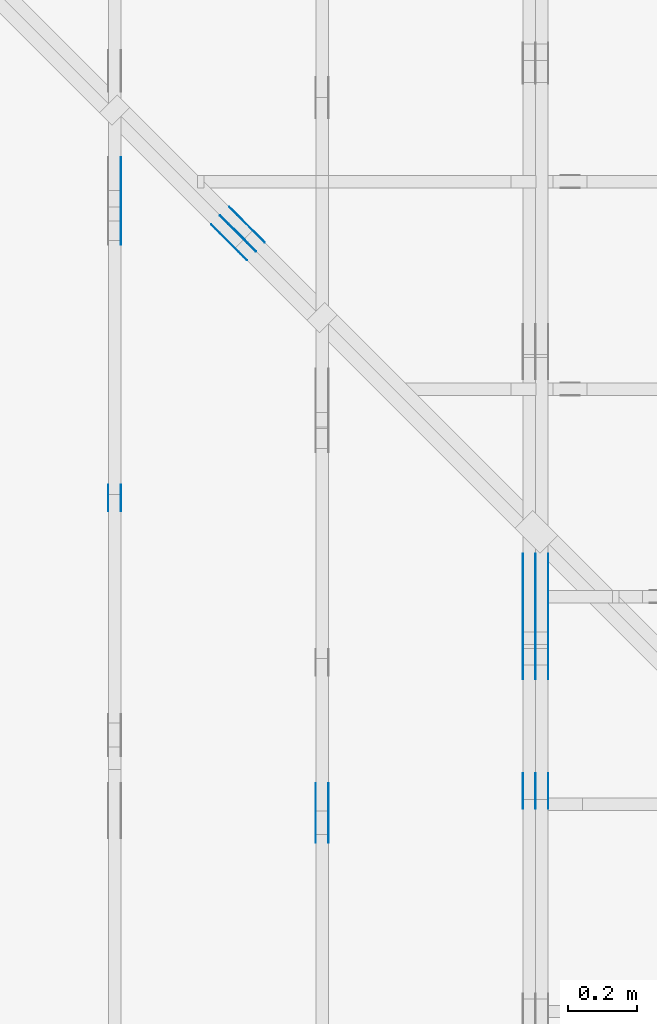
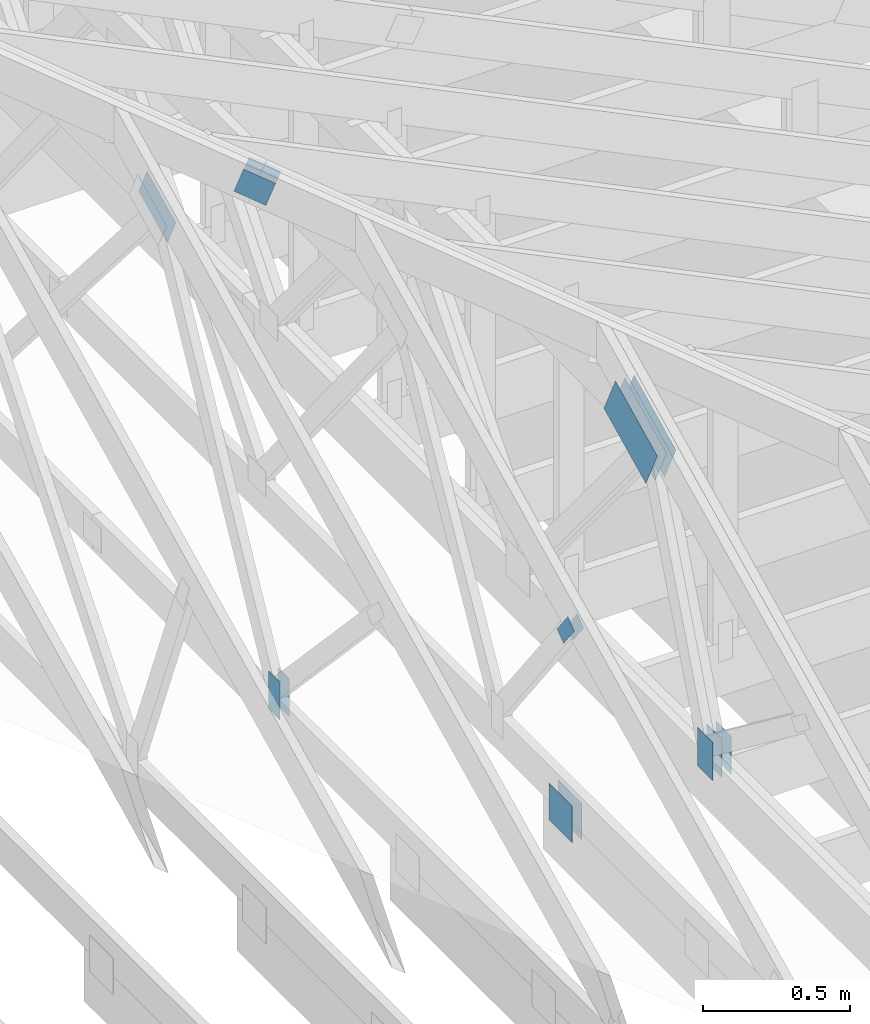
# One storey, part 115 of 159: 19 plates, 4 elements without a shape of their own.
"""IFC2X3 building model written with IfcOpenShell, lengths in millimetres."""

from ifc_helpers import new_model, si_unit, frame, origin, origin_with_axes, origin_2d, place, context, project, spatial, faceted_brep, element, aggregate, save


model = new_model("IFC2X3")

# Units and contexts
model_context = context("Model", 3, precision=1e-05, world=origin())
plan_context = context("Plan", 2, precision=1e-05, world=origin_2d())
ifc_project = project(units=[si_unit("LENGTHUNIT", "METRE", prefix="MILLI"), si_unit("AREAUNIT", "SQUARE_METRE"), si_unit("VOLUMEUNIT", "CUBIC_METRE"), si_unit("SOLIDANGLEUNIT", "STERADIAN"), si_unit("PLANEANGLEUNIT", "RADIAN"), si_unit("MASSUNIT", "GRAM"), si_unit("TIMEUNIT", "SECOND"), si_unit("THERMODYNAMICTEMPERATUREUNIT", "DEGREE_CELSIUS"), si_unit("LUMINOUSINTENSITYUNIT", "LUMEN")], contexts=[model_context, plan_context])

# Site, building, storey
site_placement = place(None, origin_with_axes())
site = spatial("IfcSite", under=ifc_project, at=site_placement, CompositionType="ELEMENT")
building_placement = place(site_placement, origin_with_axes())
building = spatial("IfcBuilding", under=site, at=building_placement, Name="Plan 1", CompositionType="ELEMENT")
storey_placement = place(building_placement, origin_with_axes())
storey = spatial("IfcBuildingStorey", under=building, at=storey_placement, Name="Etasje 1", CompositionType="ELEMENT", Elevation=0.0)

# Assembly, plates
assembly_1_placement = place(storey_placement, frame((18074.541652722903, -699.9989301294845, 4.408582873760558e-15), z_axis=(-1.0, 1.836909530733566e-16, 6.123031769111886e-17), x_axis=(-1.836909530733566e-16, -1.0, 0.0)))
assembly_1 = element("IfcElementAssembly", 1, at=assembly_1_placement, inside=storey, Name="V5 (30)", AssemblyPlace="FACTORY", PredefinedType="TRUSS")
plate_1_placement = place(assembly_1_placement, frame((-2561.626432245095, 1260.3537438661988, 0.0), z_axis=(0.0, 0.0, 1.0), x_axis=(-0.898794046299167, 0.4383711467890773, 0.0)))
plate_1 = element("IfcPlate", 2, at=plate_1_placement, Name="GNT100S 178x317", context=model_context, shape_type="Brep", body=[
    faceted_brep([(316.99999736103564, 177.99999490631035, 1.0), (0.0, 177.99999490631035, 1.0), (3.6269326301408e-05, 0.0, 1.0), (317.00003363036194, 0.0, 1.0), (0.0, 177.99999490631035, 0.0), (316.99999736103564, 177.99999490631035, 3.882002109300011e-14), (317.00003363036194, 3.26308529565722e-05, 3.882002553456485e-14), (3.6269326301408e-05, 3.26308529565722e-05, 4.44156474375613e-21), (317.0000882721888, 3.891293175545378e-05, 3.565444389546901e-30), (317.0000882721888, 3.891293175551501e-05, 1.0), (8.827218880469445e-05, 3.891293181374504e-05, 1.0), (8.827218880469445e-05, 3.891293181368381e-05, 1.128474576789396e-36), (317.0000882721888, 178.0000389129318, 0.0), (317.0000882721888, 178.0000389129318, 1.0), (317.0000882721888, 3.8912931813683826e-05, 1.0), (317.0000882721888, 3.8912931813683826e-05, 0.0), (8.827218925944179e-05, 178.00003891293147, 0.0), (8.827218925944179e-05, 178.00003891293147, 1.0), (317.0000882721888, 178.0000389129318, 1.0), (317.0000882721888, 178.0000389129318, 0.0), (8.827218880469445e-05, 3.891293181368383e-05, 7.52316384526264e-37), (8.827218880475568e-05, 3.891293181368383e-05, 1.0), (8.827218922179307e-05, 178.00003891293147, 1.0), (8.827218922173184e-05, 178.00003891293147, 2.3089936487439344e-30)], [[[0, 1, 2, 3]], [[4, 5, 6, 7]], [[8, 9, 10, 11]], [[12, 13, 14, 15]], [[16, 17, 18, 19]], [[20, 21, 22, 23]]]),
])
plate_2_placement = place(assembly_1_placement, frame((-2561.626432245095, 1260.3537438661988, -37.0), z_axis=(0.0, 0.0, 1.0), x_axis=(-0.898794046299167, 0.4383711467890773, 0.0)))
plate_2 = element("IfcPlate", 3, at=plate_2_placement, Name="GNT100S 178x317", context=model_context, shape_type="Brep", body=[
    faceted_brep([(316.99999736103564, 177.99999490631035, 1.0), (0.0, 177.99999490631035, 1.0), (3.6269326301408e-05, 0.0, 1.0), (317.00003363036194, 0.0, 1.0), (0.0, 177.99999490631035, 0.0), (316.99999736103564, 177.99999490631035, 3.882002109300011e-14), (317.00003363036194, 3.26308529565722e-05, 3.882002553456485e-14), (3.6269326301408e-05, 3.26308529565722e-05, 4.44156474375613e-21), (317.0000882721888, 3.891293175545378e-05, 3.565444389546901e-30), (317.0000882721888, 3.891293175551501e-05, 1.0), (8.827218880469445e-05, 3.891293181374504e-05, 1.0), (8.827218880469445e-05, 3.891293181368381e-05, 1.128474576789396e-36), (317.0000882721888, 178.0000389129318, 0.0), (317.0000882721888, 178.0000389129318, 1.0), (317.0000882721888, 3.8912931813683826e-05, 1.0), (317.0000882721888, 3.8912931813683826e-05, 0.0), (8.827218925944179e-05, 178.00003891293147, 0.0), (8.827218925944179e-05, 178.00003891293147, 1.0), (317.0000882721888, 178.0000389129318, 1.0), (317.0000882721888, 178.0000389129318, 0.0), (8.827218880469445e-05, 3.891293181368383e-05, 7.52316384526264e-37), (8.827218880475568e-05, 3.891293181368383e-05, 1.0), (8.827218922179307e-05, 178.00003891293147, 1.0), (8.827218922173184e-05, 178.00003891293147, 2.3089936487439344e-30)], [[[0, 1, 2, 3]], [[4, 5, 6, 7]], [[8, 9, 10, 11]], [[12, 13, 14, 15]], [[16, 17, 18, 19]], [[20, 21, 22, 23]]]),
])
plate_3_placement = place(assembly_1_placement, frame((-2561.626432245095, 1260.3537438661988, -36.0), z_axis=(0.0, 0.0, 1.0), x_axis=(-0.898794046299167, 0.4383711467890773, 0.0)))
plate_3 = element("IfcPlate", 4, at=plate_3_placement, Name="GNT100S 178x317", context=model_context, shape_type="Brep", body=[
    faceted_brep([(316.99999736103564, 177.99999490631035, 1.0), (0.0, 177.99999490631035, 1.0), (3.6269326301408e-05, 0.0, 1.0), (317.00003363036194, 0.0, 1.0), (0.0, 177.99999490631035, 0.0), (316.99999736103564, 177.99999490631035, 3.882002109300011e-14), (317.00003363036194, 3.26308529565722e-05, 3.882002553456485e-14), (3.6269326301408e-05, 3.26308529565722e-05, 4.44156474375613e-21), (317.0000882721888, 3.891293175545378e-05, 3.565444389546901e-30), (317.0000882721888, 3.891293175551501e-05, 1.0), (8.827218880469445e-05, 3.891293181374504e-05, 1.0), (8.827218880469445e-05, 3.891293181368381e-05, 1.128474576789396e-36), (317.0000882721888, 178.0000389129318, 0.0), (317.0000882721888, 178.0000389129318, 1.0), (317.0000882721888, 3.8912931813683826e-05, 1.0), (317.0000882721888, 3.8912931813683826e-05, 0.0), (8.827218925944179e-05, 178.00003891293147, 0.0), (8.827218925944179e-05, 178.00003891293147, 1.0), (317.0000882721888, 178.0000389129318, 1.0), (317.0000882721888, 178.0000389129318, 0.0), (8.827218880469445e-05, 3.891293181368383e-05, 7.52316384526264e-37), (8.827218880475568e-05, 3.891293181368383e-05, 1.0), (8.827218922179307e-05, 178.00003891293147, 1.0), (8.827218922173184e-05, 178.00003891293147, 2.3089936487439344e-30)], [[[0, 1, 2, 3]], [[4, 5, 6, 7]], [[8, 9, 10, 11]], [[12, 13, 14, 15]], [[16, 17, 18, 19]], [[20, 21, 22, 23]]]),
])
plate_4_placement = place(assembly_1_placement, frame((-2561.626432245095, 1260.3537438661988, -73.0), z_axis=(0.0, 0.0, 1.0), x_axis=(-0.898794046299167, 0.4383711467890773, 0.0)))
plate_4 = element("IfcPlate", 5, at=plate_4_placement, Name="GNT100S 178x317", context=model_context, shape_type="Brep", body=[
    faceted_brep([(316.99999736103564, 177.99999490631035, 1.0), (0.0, 177.99999490631035, 1.0), (3.6269326301408e-05, 0.0, 1.0), (317.00003363036194, 0.0, 1.0), (0.0, 177.99999490631035, 0.0), (316.99999736103564, 177.99999490631035, 3.882002109300011e-14), (317.00003363036194, 3.26308529565722e-05, 3.882002553456485e-14), (3.6269326301408e-05, 3.26308529565722e-05, 4.44156474375613e-21), (317.0000882721888, 3.891293175545378e-05, 3.565444389546901e-30), (317.0000882721888, 3.891293175551501e-05, 1.0), (8.827218880469445e-05, 3.891293181374504e-05, 1.0), (8.827218880469445e-05, 3.891293181368381e-05, 1.128474576789396e-36), (317.0000882721888, 178.0000389129318, 0.0), (317.0000882721888, 178.0000389129318, 1.0), (317.0000882721888, 3.8912931813683826e-05, 1.0), (317.0000882721888, 3.8912931813683826e-05, 0.0), (8.827218925944179e-05, 178.00003891293147, 0.0), (8.827218925944179e-05, 178.00003891293147, 1.0), (317.0000882721888, 178.0000389129318, 1.0), (317.0000882721888, 178.0000389129318, 0.0), (8.827218880469445e-05, 3.891293181368383e-05, 7.52316384526264e-37), (8.827218880475568e-05, 3.891293181368383e-05, 1.0), (8.827218922179307e-05, 178.00003891293147, 1.0), (8.827218922173184e-05, 178.00003891293147, 2.3089936487439344e-30)], [[[0, 1, 2, 3]], [[4, 5, 6, 7]], [[8, 9, 10, 11]], [[12, 13, 14, 15]], [[16, 17, 18, 19]], [[20, 21, 22, 23]]]),
])
plate_5_placement = place(assembly_1_placement, frame((-2186.5147959777787, 143.49999999999895, 0.0), z_axis=(0.0, 0.0, 1.0), x_axis=(6.123031769111886e-17, 1.0, 0.0)))
plate_5 = element("IfcPlate", 6, at=plate_5_placement, Name="GNT100S 103x159", context=model_context, shape_type="Brep", body=[
    faceted_brep([(159.00000000000108, 103.0000966003463, 1.0), (1.0516032489249483e-12, 103.0000966003463, 1.0), (1.0516032489249483e-12, 9.660034629632719e-05, 1.0), (159.00000000000108, 9.660034629632719e-05, 1.0), (1.0516032489249483e-12, 103.0000966003463, 1.2878000203337467e-28), (159.00000000000108, 103.0000966003463, 1.947124102577593e-14), (159.00000000000108, 9.660034629632719e-05, 1.947124102577593e-14), (1.0516032489249483e-12, 9.660034629632719e-05, 1.2878000203337467e-28), (159.00000000000006, -2.920686153866371e-14, 1.7883454107728996e-30), (159.00000000000006, -2.914563122097259e-14, 1.0), (1.1247455413666031e-32, 6.123031769111886e-17, 1.0), (0.0, 0.0, 0.0), (159.00000000000006, 103.0, 0.0), (159.00000000000006, 103.0, 1.0), (159.00000000000006, 0.0, 1.0), (159.00000000000006, 0.0, 0.0), (0.0, 103.0, 0.0), (-3.7491518045553436e-33, 103.0, 1.0), (159.00000000000006, 102.99999999999999, 1.0), (159.00000000000006, 102.99999999999999, -7.888609052210118e-31), (0.0, 0.0, 0.0), (6.123031769111886e-17, -7.498303609110687e-33, 1.0), (1.2674675762061605e-14, 103.0, 1.0), (1.2613445444370486e-14, 103.0, -7.723252717384008e-31)], [[[0, 1, 2, 3]], [[4, 5, 6, 7]], [[8, 9, 10, 11]], [[12, 13, 14, 15]], [[16, 17, 18, 19]], [[20, 21, 22, 23]]]),
])
plate_6_placement = place(assembly_1_placement, frame((-2186.5147959777787, 143.49999999999895, -37.0), z_axis=(0.0, 0.0, 1.0), x_axis=(6.123031769111886e-17, 1.0, 0.0)))
plate_6 = element("IfcPlate", 7, at=plate_6_placement, Name="GNT100S 103x159", context=model_context, shape_type="Brep", body=[
    faceted_brep([(159.00000000000108, 103.0000966003463, 1.0), (1.0516032489249483e-12, 103.0000966003463, 1.0), (1.0516032489249483e-12, 9.660034629632719e-05, 1.0), (159.00000000000108, 9.660034629632719e-05, 1.0), (1.0516032489249483e-12, 103.0000966003463, 1.2878000203337467e-28), (159.00000000000108, 103.0000966003463, 1.947124102577593e-14), (159.00000000000108, 9.660034629632719e-05, 1.947124102577593e-14), (1.0516032489249483e-12, 9.660034629632719e-05, 1.2878000203337467e-28), (159.00000000000006, -2.920686153866371e-14, 1.7883454107728996e-30), (159.00000000000006, -2.914563122097259e-14, 1.0), (1.1247455413666031e-32, 6.123031769111886e-17, 1.0), (0.0, 0.0, 0.0), (159.00000000000006, 103.0, 0.0), (159.00000000000006, 103.0, 1.0), (159.00000000000006, 0.0, 1.0), (159.00000000000006, 0.0, 0.0), (0.0, 103.0, 0.0), (-3.7491518045553436e-33, 103.0, 1.0), (159.00000000000006, 102.99999999999999, 1.0), (159.00000000000006, 102.99999999999999, -7.888609052210118e-31), (0.0, 0.0, 0.0), (6.123031769111886e-17, -7.498303609110687e-33, 1.0), (1.2674675762061605e-14, 103.0, 1.0), (1.2613445444370486e-14, 103.0, -7.723252717384008e-31)], [[[0, 1, 2, 3]], [[4, 5, 6, 7]], [[8, 9, 10, 11]], [[12, 13, 14, 15]], [[16, 17, 18, 19]], [[20, 21, 22, 23]]]),
])
plate_7_placement = place(assembly_1_placement, frame((-2186.5147959777787, 143.49999999999895, -36.0), z_axis=(0.0, 0.0, 1.0), x_axis=(6.123031769111886e-17, 1.0, 0.0)))
plate_7 = element("IfcPlate", 8, at=plate_7_placement, Name="GNT100S 103x159", context=model_context, shape_type="Brep", body=[
    faceted_brep([(159.00000000000108, 103.0000966003463, 1.0), (1.0516032489249483e-12, 103.0000966003463, 1.0), (1.0516032489249483e-12, 9.660034629632719e-05, 1.0), (159.00000000000108, 9.660034629632719e-05, 1.0), (1.0516032489249483e-12, 103.0000966003463, 1.2878000203337467e-28), (159.00000000000108, 103.0000966003463, 1.947124102577593e-14), (159.00000000000108, 9.660034629632719e-05, 1.947124102577593e-14), (1.0516032489249483e-12, 9.660034629632719e-05, 1.2878000203337467e-28), (159.00000000000006, -2.920686153866371e-14, 1.7883454107728996e-30), (159.00000000000006, -2.914563122097259e-14, 1.0), (1.1247455413666031e-32, 6.123031769111886e-17, 1.0), (0.0, 0.0, 0.0), (159.00000000000006, 103.0, 0.0), (159.00000000000006, 103.0, 1.0), (159.00000000000006, 0.0, 1.0), (159.00000000000006, 0.0, 0.0), (0.0, 103.0, 0.0), (-3.7491518045553436e-33, 103.0, 1.0), (159.00000000000006, 102.99999999999999, 1.0), (159.00000000000006, 102.99999999999999, -7.888609052210118e-31), (0.0, 0.0, 0.0), (6.123031769111886e-17, -7.498303609110687e-33, 1.0), (1.2674675762061605e-14, 103.0, 1.0), (1.2613445444370486e-14, 103.0, -7.723252717384008e-31)], [[[0, 1, 2, 3]], [[4, 5, 6, 7]], [[8, 9, 10, 11]], [[12, 13, 14, 15]], [[16, 17, 18, 19]], [[20, 21, 22, 23]]]),
])
plate_8_placement = place(assembly_1_placement, frame((-2186.5147959777787, 143.49999999999895, -73.0), z_axis=(0.0, 0.0, 1.0), x_axis=(6.123031769111886e-17, 1.0, 0.0)))
plate_8 = element("IfcPlate", 9, at=plate_8_placement, Name="GNT100S 103x159", context=model_context, shape_type="Brep", body=[
    faceted_brep([(159.00000000000108, 103.0000966003463, 1.0), (1.0516032489249483e-12, 103.0000966003463, 1.0), (1.0516032489249483e-12, 9.660034629632719e-05, 1.0), (159.00000000000108, 9.660034629632719e-05, 1.0), (1.0516032489249483e-12, 103.0000966003463, 1.2878000203337467e-28), (159.00000000000108, 103.0000966003463, 1.947124102577593e-14), (159.00000000000108, 9.660034629632719e-05, 1.947124102577593e-14), (1.0516032489249483e-12, 9.660034629632719e-05, 1.2878000203337467e-28), (159.00000000000006, -2.920686153866371e-14, 1.7883454107728996e-30), (159.00000000000006, -2.914563122097259e-14, 1.0), (1.1247455413666031e-32, 6.123031769111886e-17, 1.0), (0.0, 0.0, 0.0), (159.00000000000006, 103.0, 0.0), (159.00000000000006, 103.0, 1.0), (159.00000000000006, 0.0, 1.0), (159.00000000000006, 0.0, 0.0), (0.0, 103.0, 0.0), (-3.7491518045553436e-33, 103.0, 1.0), (159.00000000000006, 102.99999999999999, 1.0), (159.00000000000006, 102.99999999999999, -7.888609052210118e-31), (0.0, 0.0, 0.0), (6.123031769111886e-17, -7.498303609110687e-33, 1.0), (1.2674675762061605e-14, 103.0, 1.0), (1.2613445444370486e-14, 103.0, -7.723252717384008e-31)], [[[0, 1, 2, 3]], [[4, 5, 6, 7]], [[8, 9, 10, 11]], [[12, 13, 14, 15]], [[16, 17, 18, 19]], [[20, 21, 22, 23]]]),
])
aggregate(assembly_1, [plate_1, plate_2, plate_3, plate_4, plate_5, plate_6, plate_7, plate_8])

assembly_2_placement = place(storey_placement, frame((17475.02226140475, -699.9989301294827, 1.1021457184401395e-15), z_axis=(-1.0, 1.836909530733566e-16, 6.123031769111886e-17), x_axis=(-1.836909530733566e-16, -1.0, 0.0)))
assembly_2 = element("IfcElementAssembly", 10, at=assembly_2_placement, inside=storey, Name="V6 (31)", AssemblyPlace="FACTORY", PredefinedType="TRUSS")
plate_9_placement = place(assembly_2_placement, frame((-2260.0010698705446, 146.9999999999998, 0.0), z_axis=(0.0, 0.0, 1.0), x_axis=(1.0, 0.0, 0.0)))
plate_9 = element("IfcPlate", 11, at=plate_9_placement, Name="GNT100S 152x159", context=model_context, shape_type="Brep", body=[
    faceted_brep([(159.0000933080446, 152.0000000000002, 1.0), (9.330804459750652e-05, 152.0000000000002, 1.0), (9.330804459750652e-05, 1.9895196601282805e-13, 1.0), (159.0000933080446, 1.9895196601282805e-13, 1.0), (9.330804459750652e-05, 152.0000000000002, 1.1426562427684823e-20), (159.0000933080446, 152.0000000000002, 1.9471252452338226e-14), (159.0000933080446, 1.9895196601282805e-13, 1.9471252452338226e-14), (9.330804459750652e-05, 1.9895196601282805e-13, 1.1426562427684823e-20), (159.0, -2.92068615386637e-14, 1.788345410772899e-30), (159.0, -2.914563122097258e-14, 1.0), (1.1247455413666031e-32, 6.123031769111886e-17, 1.0), (0.0, 0.0, 0.0), (159.0, 151.99999999999997, 0.0), (159.0, 151.99999999999997, 1.0), (159.0, 0.0, 1.0), (159.0, 0.0, 0.0), (0.0, 151.99999999999997, 0.0), (-3.7491518045553436e-33, 151.99999999999997, 1.0), (159.0, 151.99999999999997, 1.0), (159.0, 151.99999999999997, 0.0), (0.0, 0.0, 0.0), (6.123031769111886e-17, -7.498303609110687e-33, 1.0), (1.867524689579125e-14, 151.99999999999997, 1.0), (1.861401657810013e-14, 151.99999999999997, -1.1397421485848243e-30)], [[[0, 1, 2, 3]], [[4, 5, 6, 7]], [[8, 9, 10, 11]], [[12, 13, 14, 15]], [[16, 17, 18, 19]], [[20, 21, 22, 23]]]),
])
plate_10_placement = place(assembly_2_placement, frame((-2260.0010698705446, 146.9999999999998, -37.0), z_axis=(0.0, 0.0, 1.0), x_axis=(1.0, 0.0, 0.0)))
plate_10 = element("IfcPlate", 12, at=plate_10_placement, Name="GNT100S 152x159", context=model_context, shape_type="Brep", body=[
    faceted_brep([(159.0000933080446, 152.0000000000002, 1.0), (9.330804459750652e-05, 152.0000000000002, 1.0), (9.330804459750652e-05, 1.9895196601282805e-13, 1.0), (159.0000933080446, 1.9895196601282805e-13, 1.0), (9.330804459750652e-05, 152.0000000000002, 1.1426562427684823e-20), (159.0000933080446, 152.0000000000002, 1.9471252452338226e-14), (159.0000933080446, 1.9895196601282805e-13, 1.9471252452338226e-14), (9.330804459750652e-05, 1.9895196601282805e-13, 1.1426562427684823e-20), (159.0, -2.92068615386637e-14, 1.788345410772899e-30), (159.0, -2.914563122097258e-14, 1.0), (1.1247455413666031e-32, 6.123031769111886e-17, 1.0), (0.0, 0.0, 0.0), (159.0, 151.99999999999997, 0.0), (159.0, 151.99999999999997, 1.0), (159.0, 0.0, 1.0), (159.0, 0.0, 0.0), (0.0, 151.99999999999997, 0.0), (-3.7491518045553436e-33, 151.99999999999997, 1.0), (159.0, 151.99999999999997, 1.0), (159.0, 151.99999999999997, 0.0), (0.0, 0.0, 0.0), (6.123031769111886e-17, -7.498303609110687e-33, 1.0), (1.867524689579125e-14, 151.99999999999997, 1.0), (1.861401657810013e-14, 151.99999999999997, -1.1397421485848243e-30)], [[[0, 1, 2, 3]], [[4, 5, 6, 7]], [[8, 9, 10, 11]], [[12, 13, 14, 15]], [[16, 17, 18, 19]], [[20, 21, 22, 23]]]),
])
plate_11_placement = place(assembly_2_placement, frame((-2131.4587961600714, 1065.8656433826886, 0.0), z_axis=(0.0, 0.0, 1.0), x_axis=(-0.6077192601697482, -0.7941519381193588, 0.0)))
plate_11 = element("IfcPlate", 13, at=plate_11_placement, Name="GNT100S 55x119", context=model_context, shape_type="Brep", body=[
    faceted_brep([(119.00009632777835, 54.99996480502614, 1.0), (8.238090265422215e-05, 54.99996480502614, 1.0), (0.0, 7.042191009531962e-05, 1.0), (119.00001394687536, 7.042191009531962e-05, 1.0), (8.238090265422215e-05, 54.99996480502614, 1.008841768239832e-20), (119.00009632777835, 54.99996480502614, 1.457282740684723e-14), (119.00001394687536, 6.654401249761577e-05, 1.4572817318429506e-14), (0.0, 6.654401249761577e-05, 0.0), (119.00009762190109, -2.1859241347989487e-14, 1.3384482922242376e-30), (119.00009762190109, -2.179801103029837e-14, 1.0), (9.762190109086077e-05, 6.121238543106665e-17, 1.0), (9.762190109086077e-05, -1.7932260052213165e-20, 1.0979979799167717e-36), (119.00009762190109, 55.0, 6.310887241768095e-30), (119.00009762190109, 55.0, 1.0), (119.00009762190109, 0.0, 1.0), (119.00009762190109, 0.0, 0.0), (9.762190109086077e-05, 55.0, 0.0), (9.762190109086077e-05, 55.0, 1.0), (119.00009762190098, 54.99999999999999, 1.0), (119.00009762190098, 54.99999999999999, -3.944304526105059e-31), (9.762190109086077e-05, 0.0, 0.0), (9.7621901090922e-05, -7.498303609110687e-33, 1.0), (9.762190109765734e-05, 55.0, 1.0), (9.762190109759611e-05, 55.0, -4.12407052618761e-31)], [[[0, 1, 2, 3]], [[4, 5, 6, 7]], [[8, 9, 10, 11]], [[12, 13, 14, 15]], [[16, 17, 18, 19]], [[20, 21, 22, 23]]]),
])
plate_12_placement = place(assembly_2_placement, frame((-2131.4587961600714, 1065.8656433826886, -37.0), z_axis=(0.0, 0.0, 1.0), x_axis=(-0.6077192601697482, -0.7941519381193588, 0.0)))
plate_12 = element("IfcPlate", 14, at=plate_12_placement, Name="GNT100S 55x119", context=model_context, shape_type="Brep", body=[
    faceted_brep([(119.00009632777835, 54.99996480502614, 1.0), (8.238090265422215e-05, 54.99996480502614, 1.0), (0.0, 7.042191009531962e-05, 1.0), (119.00001394687536, 7.042191009531962e-05, 1.0), (8.238090265422215e-05, 54.99996480502614, 1.008841768239832e-20), (119.00009632777835, 54.99996480502614, 1.457282740684723e-14), (119.00001394687536, 6.654401249761577e-05, 1.4572817318429506e-14), (0.0, 6.654401249761577e-05, 0.0), (119.00009762190109, -2.1859241347989487e-14, 1.3384482922242376e-30), (119.00009762190109, -2.179801103029837e-14, 1.0), (9.762190109086077e-05, 6.121238543106665e-17, 1.0), (9.762190109086077e-05, -1.7932260052213165e-20, 1.0979979799167717e-36), (119.00009762190109, 55.0, 6.310887241768095e-30), (119.00009762190109, 55.0, 1.0), (119.00009762190109, 0.0, 1.0), (119.00009762190109, 0.0, 0.0), (9.762190109086077e-05, 55.0, 0.0), (9.762190109086077e-05, 55.0, 1.0), (119.00009762190098, 54.99999999999999, 1.0), (119.00009762190098, 54.99999999999999, -3.944304526105059e-31), (9.762190109086077e-05, 0.0, 0.0), (9.7621901090922e-05, -7.498303609110687e-33, 1.0), (9.762190109765734e-05, 55.0, 1.0), (9.762190109759611e-05, 55.0, -4.12407052618761e-31)], [[[0, 1, 2, 3]], [[4, 5, 6, 7]], [[8, 9, 10, 11]], [[12, 13, 14, 15]], [[16, 17, 18, 19]], [[20, 21, 22, 23]]]),
])
aggregate(assembly_2, [plate_9, plate_10, plate_11, plate_12])

assembly_3_placement = place(storey_placement, frame((16875.02226140475, -699.9989301294827, 1.1021457184401395e-15), z_axis=(-1.0, 1.836909530733566e-16, 6.123031769111886e-17), x_axis=(-1.836909530733566e-16, -1.0, 0.0)))
assembly_3 = element("IfcElementAssembly", 15, at=assembly_3_placement, inside=storey, Name="V7 (32)", AssemblyPlace="FACTORY", PredefinedType="TRUSS")
plate_13_placement = place(assembly_3_placement, frame((-3817.908173383582, 1873.0833129320708, -37.0), z_axis=(0.0, 0.0, 1.0), x_axis=(-0.8987940462991673, 0.4383711467890769, 0.0)))
plate_13 = element("IfcPlate", 16, at=plate_13_placement, Name="GNT100S 130x218", context=model_context, shape_type="Brep", body=[
    faceted_brep([(217.9999458016482, 130.0001140333818, 1.0), (1.3262097127153538e-05, 130.0001140333818, 1.0), (0.0, 6.784529296055553e-05, 1.0), (217.99993253955017, 6.784529296055553e-05, 1.0), (1.3262097127153538e-05, 130.0001140333818, 1.6240848406921719e-21), (217.9999458016482, 130.0001140333818, 2.6696411876163228e-14), (217.99993253955017, 0.0, 2.6696410252078276e-14), (0.0, 0.0, 0.0), (218.00002108147146, 6.002692176113711e-05, 2.451945798866077e-30), (218.00002108147146, 6.002692176119834e-05, 1.0), (2.1081471459183376e-05, 6.0026921801242966e-05, 1.0), (2.1081471459183376e-05, 6.0026921801181736e-05, 0.0), (218.00002108147146, 130.0000600269218, 5.679798517591285e-29), (218.00002108147146, 130.0000600269218, 1.0), (218.00002108147146, 6.002692180118174e-05, 1.0), (218.00002108147146, 6.002692180118174e-05, 0.0), (2.1081471459183376e-05, 130.00006002692157, 0.0), (2.1081471459183376e-05, 130.00006002692157, 1.0), (218.00002108147055, 130.0000600269218, 1.0), (218.00002108147055, 130.0000600269218, 0.0), (2.1081471459183383e-05, 6.002692180118174e-05, -3.76158192263132e-37), (2.1081471459244613e-05, 6.002692180118174e-05, 1.0), (2.1081471475164496e-05, 130.00006002692157, 1.0), (2.1081471475103266e-05, 130.00006002692157, -9.747799129335068e-31)], [[[0, 1, 2, 3]], [[4, 5, 6, 7]], [[8, 9, 10, 11]], [[12, 13, 14, 15]], [[16, 17, 18, 19]], [[20, 21, 22, 23]]]),
])
plate_14_placement = place(assembly_3_placement, frame((-3047.2331420325972, 291.49999999999903, 0.0), z_axis=(0.0, 0.0, 1.0), x_axis=(6.123031769111886e-17, 1.0, 0.0)))
plate_14 = element("IfcPlate", 17, at=plate_14_placement, Name="GNT100S 76x159", context=model_context, shape_type="Brep", body=[
    faceted_brep([(159.00000000000097, 76.00001226427776, 1.0), (9.663381206337363e-13, 76.00001226427776, 1.0), (9.663381206337363e-13, 1.2264277756912634e-05, 1.0), (159.00000000000097, 1.2264277756912634e-05, 1.0), (9.663381206337363e-13, 76.00001226427776, 1.1833838024688483e-28), (159.00000000000097, 76.00001226427776, 1.9471241025775918e-14), (159.00000000000097, 1.2264277756912634e-05, 1.9471241025775918e-14), (9.663381206337363e-13, 1.2264277756912634e-05, 1.1833838024688483e-28), (159.0, -2.92068615386637e-14, 1.788345410772899e-30), (159.0, -2.914563122097258e-14, 1.0), (1.1247455413666031e-32, 6.123031769111886e-17, 1.0), (0.0, 0.0, 0.0), (159.0, 76.0, 0.0), (159.0, 76.0, 1.0), (159.0, 0.0, 1.0), (159.0, 0.0, 0.0), (0.0, 76.0, 0.0), (-3.7491518045553436e-33, 76.0, 1.0), (159.0, 75.99999999999999, 1.0), (159.0, 75.99999999999999, -7.888609052210118e-31), (0.0, 0.0, 0.0), (6.123031769111886e-17, -7.498303609110687e-33, 1.0), (9.368238606741186e-15, 76.0, 1.0), (9.307008289050067e-15, 76.0, -5.698710742924122e-31)], [[[0, 1, 2, 3]], [[4, 5, 6, 7]], [[8, 9, 10, 11]], [[12, 13, 14, 15]], [[16, 17, 18, 19]], [[20, 21, 22, 23]]]),
])
plate_15_placement = place(assembly_3_placement, frame((-3047.2331420325972, 291.49999999999903, -37.0), z_axis=(0.0, 0.0, 1.0), x_axis=(6.123031769111886e-17, 1.0, 0.0)))
plate_15 = element("IfcPlate", 18, at=plate_15_placement, Name="GNT100S 76x159", context=model_context, shape_type="Brep", body=[
    faceted_brep([(159.00000000000097, 76.00001226427776, 1.0), (9.663381206337363e-13, 76.00001226427776, 1.0), (9.663381206337363e-13, 1.2264277756912634e-05, 1.0), (159.00000000000097, 1.2264277756912634e-05, 1.0), (9.663381206337363e-13, 76.00001226427776, 1.1833838024688483e-28), (159.00000000000097, 76.00001226427776, 1.9471241025775918e-14), (159.00000000000097, 1.2264277756912634e-05, 1.9471241025775918e-14), (9.663381206337363e-13, 1.2264277756912634e-05, 1.1833838024688483e-28), (159.0, -2.92068615386637e-14, 1.788345410772899e-30), (159.0, -2.914563122097258e-14, 1.0), (1.1247455413666031e-32, 6.123031769111886e-17, 1.0), (0.0, 0.0, 0.0), (159.0, 76.0, 0.0), (159.0, 76.0, 1.0), (159.0, 0.0, 1.0), (159.0, 0.0, 0.0), (0.0, 76.0, 0.0), (-3.7491518045553436e-33, 76.0, 1.0), (159.0, 75.99999999999999, 1.0), (159.0, 75.99999999999999, -7.888609052210118e-31), (0.0, 0.0, 0.0), (6.123031769111886e-17, -7.498303609110687e-33, 1.0), (9.368238606741186e-15, 76.0, 1.0), (9.307008289050067e-15, 76.0, -5.698710742924122e-31)], [[[0, 1, 2, 3]], [[4, 5, 6, 7]], [[8, 9, 10, 11]], [[12, 13, 14, 15]], [[16, 17, 18, 19]], [[20, 21, 22, 23]]]),
])
aggregate(assembly_3, [plate_13, plate_14, plate_15])

assembly_4_placement = place(storey_placement, frame((21125.46850722421, -674.5430860067681, 2.204291436880279e-15), z_axis=(0.707106781186546, 0.707106781186549, 6.123031769111886e-17), x_axis=(-0.707106781186549, 0.707106781186546, 0.0)))
assembly_4 = element("IfcElementAssembly", 19, at=assembly_4_placement, inside=storey, Name="GR1 (35)", AssemblyPlace="FACTORY", PredefinedType="TRUSS")
plate_16_placement = place(assembly_4_placement, frame((5405.349966255167, 1839.0221714793984, 0.0), z_axis=(0.0, 0.0, 1.0), x_axis=(0.9453579955214152, 0.32603413978252627, 0.0)))
plate_16 = element("IfcPlate", 20, at=plate_16_placement, Name="GNT100S 103x119", context=model_context, shape_type="Brep", body=[
    faceted_brep([(119.00006868466426, 102.99996388448972, 1.0), (9.843365569395246e-05, 102.99996388448972, 1.0), (0.0001389961080349167, 0.0, 1.0), (119.0001092471175, 0.0, 1.0), (9.843365569395246e-05, 102.99996388448972, 1.205424801927784e-20), (119.00006868466426, 102.99996388448972, 1.4572824021653914e-14), (119.0001092471175, 4.524020664575801e-05, 1.4572828988957714e-14), (0.0001389961080349167, 4.524020664575801e-05, 1.7021551705614056e-20), (119.0, 4.315270027833824e-05, 1.338447208185253e-30), (119.0, 4.315270027839947e-05, 1.0), (1.1247455413666031e-32, 4.3152700300258697e-05, 1.0), (0.0, 4.3152700300197466e-05, 0.0), (119.0, 103.0000431527003, 5.522026336547083e-29), (119.0, 103.0000431527003, 1.0), (119.0, 4.3152700300197466e-05, 1.0), (119.0, 4.3152700300197466e-05, 0.0), (0.0, 103.0000431527003, 0.0), (-3.7491518045553436e-33, 103.0000431527003, 1.0), (118.99999999999909, 103.00004315270029, 1.0), (118.99999999999909, 103.00004315270029, -7.888609052210118e-31), (5.284507097221462e-21, 4.3152700300197466e-05, -3.235720484038425e-37), (6.123560219821608e-17, 4.3152700300197466e-05, 1.0), (1.2674681046568702e-14, 103.0000431527003, 1.0), (1.2613450728877583e-14, 103.0000431527003, -7.723255953104492e-31)], [[[0, 1, 2, 3]], [[4, 5, 6, 7]], [[8, 9, 10, 11]], [[12, 13, 14, 15]], [[16, 17, 18, 19]], [[20, 21, 22, 23]]]),
])
plate_17_placement = place(assembly_4_placement, frame((5405.349966255167, 1839.0221714793984, -36.99999999999999), z_axis=(0.0, 0.0, 1.0), x_axis=(0.9453579955214152, 0.32603413978252627, 0.0)))
plate_17 = element("IfcPlate", 21, at=plate_17_placement, Name="GNT100S 103x119", context=model_context, shape_type="Brep", body=[
    faceted_brep([(119.00006868466426, 102.99996388448972, 1.0), (9.843365569395246e-05, 102.99996388448972, 1.0), (0.0001389961080349167, 0.0, 1.0), (119.0001092471175, 0.0, 1.0), (9.843365569395246e-05, 102.99996388448972, 1.205424801927784e-20), (119.00006868466426, 102.99996388448972, 1.4572824021653914e-14), (119.0001092471175, 4.524020664575801e-05, 1.4572828988957714e-14), (0.0001389961080349167, 4.524020664575801e-05, 1.7021551705614056e-20), (119.0, 4.315270027833824e-05, 1.338447208185253e-30), (119.0, 4.315270027839947e-05, 1.0), (1.1247455413666031e-32, 4.3152700300258697e-05, 1.0), (0.0, 4.3152700300197466e-05, 0.0), (119.0, 103.0000431527003, 5.522026336547083e-29), (119.0, 103.0000431527003, 1.0), (119.0, 4.3152700300197466e-05, 1.0), (119.0, 4.3152700300197466e-05, 0.0), (0.0, 103.0000431527003, 0.0), (-3.7491518045553436e-33, 103.0000431527003, 1.0), (118.99999999999909, 103.00004315270029, 1.0), (118.99999999999909, 103.00004315270029, -7.888609052210118e-31), (5.284507097221462e-21, 4.3152700300197466e-05, -3.235720484038425e-37), (6.123560219821608e-17, 4.3152700300197466e-05, 1.0), (1.2674681046568702e-14, 103.0000431527003, 1.0), (1.2613450728877583e-14, 103.0000431527003, -7.723255953104492e-31)], [[[0, 1, 2, 3]], [[4, 5, 6, 7]], [[8, 9, 10, 11]], [[12, 13, 14, 15]], [[16, 17, 18, 19]], [[20, 21, 22, 23]]]),
])
plate_18_placement = place(assembly_4_placement, frame((5405.349966255167, 1839.0221714793984, -35.99999999999999), z_axis=(0.0, 0.0, 1.0), x_axis=(0.9453579955214152, 0.32603413978252627, 0.0)))
plate_18 = element("IfcPlate", 22, at=plate_18_placement, Name="GNT100S 103x119", context=model_context, shape_type="Brep", body=[
    faceted_brep([(119.00006868466426, 102.99996388448972, 1.0), (9.843365569395246e-05, 102.99996388448972, 1.0), (0.0001389961080349167, 0.0, 1.0), (119.0001092471175, 0.0, 1.0), (9.843365569395246e-05, 102.99996388448972, 1.205424801927784e-20), (119.00006868466426, 102.99996388448972, 1.4572824021653914e-14), (119.0001092471175, 4.524020664575801e-05, 1.4572828988957714e-14), (0.0001389961080349167, 4.524020664575801e-05, 1.7021551705614056e-20), (119.0, 4.315270027833824e-05, 1.338447208185253e-30), (119.0, 4.315270027839947e-05, 1.0), (1.1247455413666031e-32, 4.3152700300258697e-05, 1.0), (0.0, 4.3152700300197466e-05, 0.0), (119.0, 103.0000431527003, 5.522026336547083e-29), (119.0, 103.0000431527003, 1.0), (119.0, 4.3152700300197466e-05, 1.0), (119.0, 4.3152700300197466e-05, 0.0), (0.0, 103.0000431527003, 0.0), (-3.7491518045553436e-33, 103.0000431527003, 1.0), (118.99999999999909, 103.00004315270029, 1.0), (118.99999999999909, 103.00004315270029, -7.888609052210118e-31), (5.284507097221462e-21, 4.3152700300197466e-05, -3.235720484038425e-37), (6.123560219821608e-17, 4.3152700300197466e-05, 1.0), (1.2674681046568702e-14, 103.0000431527003, 1.0), (1.2613450728877583e-14, 103.0000431527003, -7.723255953104492e-31)], [[[0, 1, 2, 3]], [[4, 5, 6, 7]], [[8, 9, 10, 11]], [[12, 13, 14, 15]], [[16, 17, 18, 19]], [[20, 21, 22, 23]]]),
])
plate_19_placement = place(assembly_4_placement, frame((5405.349966255167, 1839.0221714793984, -73.0), z_axis=(0.0, 0.0, 1.0), x_axis=(0.9453579955214152, 0.32603413978252627, 0.0)))
plate_19 = element("IfcPlate", 23, at=plate_19_placement, Name="GNT100S 103x119", context=model_context, shape_type="Brep", body=[
    faceted_brep([(119.00006868466426, 102.99996388448972, 1.0), (9.843365569395246e-05, 102.99996388448972, 1.0), (0.0001389961080349167, 0.0, 1.0), (119.0001092471175, 0.0, 1.0), (9.843365569395246e-05, 102.99996388448972, 1.205424801927784e-20), (119.00006868466426, 102.99996388448972, 1.4572824021653914e-14), (119.0001092471175, 4.524020664575801e-05, 1.4572828988957714e-14), (0.0001389961080349167, 4.524020664575801e-05, 1.7021551705614056e-20), (119.0, 4.315270027833824e-05, 1.338447208185253e-30), (119.0, 4.315270027839947e-05, 1.0), (1.1247455413666031e-32, 4.3152700300258697e-05, 1.0), (0.0, 4.3152700300197466e-05, 0.0), (119.0, 103.0000431527003, 5.522026336547083e-29), (119.0, 103.0000431527003, 1.0), (119.0, 4.3152700300197466e-05, 1.0), (119.0, 4.3152700300197466e-05, 0.0), (0.0, 103.0000431527003, 0.0), (-3.7491518045553436e-33, 103.0000431527003, 1.0), (118.99999999999909, 103.00004315270029, 1.0), (118.99999999999909, 103.00004315270029, -7.888609052210118e-31), (5.284507097221462e-21, 4.3152700300197466e-05, -3.235720484038425e-37), (6.123560219821608e-17, 4.3152700300197466e-05, 1.0), (1.2674681046568702e-14, 103.0000431527003, 1.0), (1.2613450728877583e-14, 103.0000431527003, -7.723255953104492e-31)], [[[0, 1, 2, 3]], [[4, 5, 6, 7]], [[8, 9, 10, 11]], [[12, 13, 14, 15]], [[16, 17, 18, 19]], [[20, 21, 22, 23]]]),
])
aggregate(assembly_4, [plate_16, plate_17, plate_18, plate_19])

save(model, "model.ifc")
